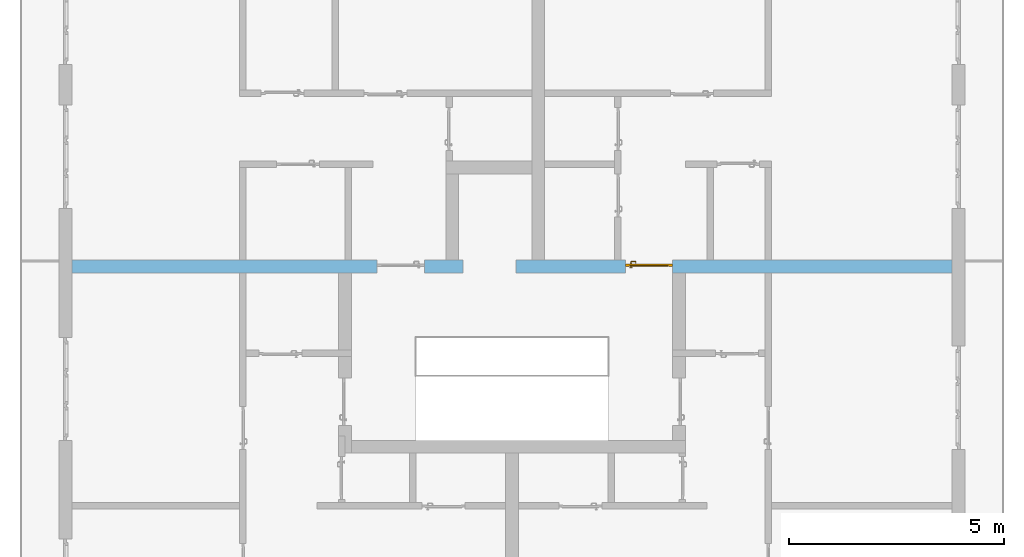
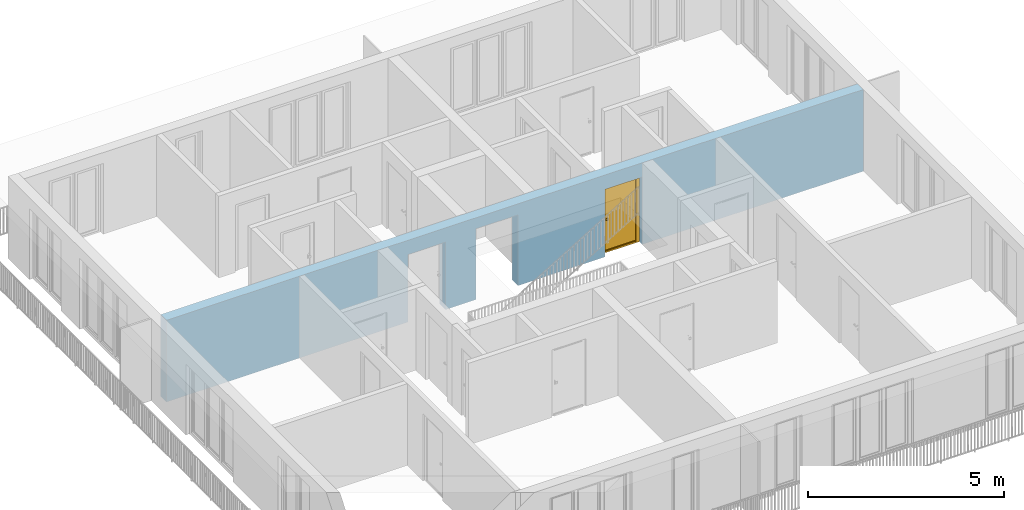
# One storey, part 17 of 54: 1 door, 3 openings, plus 1 element that does not belong to this part.
"""IFC4 building model written with IfcOpenShell, lengths in metres."""

import ifcopenshell
import ifcopenshell.guid

model = None  # the IFC model being written
_history = None  # IfcOwnerHistory: only IFC2X3 demands one
_inside = {}  # id of a spatial element -> (the spatial element, [elements in it])
_under = {}  # id of a project, library or spatial element -> (it, [spatial elements below it])
_declared = {}  # id of a project -> (the project, [libraries it declares])
_typed = {}  # id of a type object -> (the type object, [elements of that type])
_made_of = {}  # id of a material, layer set ... -> (it, [elements and type objects made of it])


def new_model(schema):
    """Start an empty IFC model of exactly this schema.

    Asked for "IFC4X3", IfcOpenShell would pick the latest addendum, in which some entities
    have other attributes; the version numbers below select the first issue.
    IFC2X3 requires an IfcOwnerHistory on every rooted entity: one is made here for all.
    """
    global model, _history
    if schema == "IFC4X3":
        model = ifcopenshell.file(schema_version=(4, 3, 0, 0))
    else:
        model = ifcopenshell.file(schema=schema)
    _inside.clear()
    _under.clear()
    _declared.clear()
    _typed.clear()
    _made_of.clear()
    _history = None
    if model.schema == "IFC2X3":
        org = make("IfcOrganization", Name="unknown")
        user = make(
            "IfcPersonAndOrganization",
            ThePerson=make("IfcPerson", FamilyName="unknown"),
            TheOrganization=org,
        )
        app = make(
            "IfcApplication",
            ApplicationDeveloper=org,
            Version="unknown",
            ApplicationFullName="unknown",
            ApplicationIdentifier="unknown",
        )
        _history = make(
            "IfcOwnerHistory",
            OwningUser=user,
            OwningApplication=app,
            ChangeAction="ADDED",
            CreationDate=0,
        )
    return model


def make(cls, **values):
    """One entity of the class cls with the attributes given. An attribute that is None is left unset."""
    return model.create_entity(
        cls, **{name: value for name, value in values.items() if value is not None}
    )


def entity(cls, *values):
    """Any entity or typed value of the class cls, its attributes in the order of the schema. None: left unset."""
    e = model.create_entity(cls)
    for i, value in enumerate(values):
        if value is not None:
            e[i] = value
    return e


def rooted(cls, **values):
    """An entity with a GlobalId (a new one), such as an element, a storey or a relation."""
    return make(cls, GlobalId=ifcopenshell.guid.new(), OwnerHistory=_history, **values)


def si_unit(unit_type, name, prefix=None):
    """IfcSIUnit, for example si_unit("LENGTHUNIT", "METRE", prefix="MILLI")."""
    return make("IfcSIUnit", UnitType=unit_type, Prefix=prefix, Name=name)


def converted_unit(unit_type, name, factor, base, dimensions=None, offset=None):
    """IfcConversionBasedUnit, such as the inch: factor (a typed value) times the base unit."""
    return make(
        "IfcConversionBasedUnit"
        if offset is None
        else "IfcConversionBasedUnitWithOffset",
        ConversionOffset=offset,
        Dimensions=None
        if dimensions is None
        else entity("IfcDimensionalExponents", *dimensions),
        UnitType=unit_type,
        Name=name,
        ConversionFactor=make(
            "IfcMeasureWithUnit", ValueComponent=factor, UnitComponent=base
        ),
    )


def derived_unit(unit_type, elements):
    """IfcDerivedUnit: a product of units, each with its exponent."""
    return make(
        "IfcDerivedUnit",
        Elements=[
            make("IfcDerivedUnitElement", Unit=unit, Exponent=power)
            for unit, power in elements
        ],
        UnitType=unit_type,
    )


def assignment(units):
    """IfcUnitAssignment: the units of a project."""
    return None if units is None else make("IfcUnitAssignment", Units=units)


def point(xyz):
    """IfcCartesianPoint."""
    return None if xyz is None else make("IfcCartesianPoint", Coordinates=xyz)


def direction(xyz):
    """IfcDirection."""
    return None if xyz is None else make("IfcDirection", DirectionRatios=xyz)


def frame(location, z_axis=None, x_axis=None):
    """IfcAxis2Placement3D, a coordinate frame: its origin and axes. An axis left out is left unset."""
    return make(
        "IfcAxis2Placement3D",
        Location=point(location),
        Axis=direction(z_axis),
        RefDirection=direction(x_axis),
    )


def origin_with_axes():
    """The frame at (0, 0, 0) with the z axis (0, 0, 1) and the x axis (1, 0, 0) written out."""
    return frame((0.0, 0.0, 0.0), z_axis=(0.0, 0.0, 1.0), x_axis=(1.0, 0.0, 0.0))


def place(relative_to, where):
    """IfcLocalPlacement: puts the frame where relative to a parent placement (None: the world)."""
    return make(
        "IfcLocalPlacement", PlacementRelTo=relative_to, RelativePlacement=where
    )


def context(
    kind, dimensions, precision=None, world=None, true_north=None, identifier=None
):
    """IfcGeometricRepresentationContext, for example the 3D "Model" context."""
    return make(
        "IfcGeometricRepresentationContext",
        ContextIdentifier=identifier,
        ContextType=kind,
        CoordinateSpaceDimension=dimensions,
        Precision=precision,
        WorldCoordinateSystem=world,
        TrueNorth=true_north,
    )


def subcontext(parent, identifier, kind, view, scale=None):
    """IfcGeometricRepresentationSubContext, for example "Body" below "Model"."""
    return make(
        "IfcGeometricRepresentationSubContext",
        ContextIdentifier=identifier,
        ContextType=kind,
        ParentContext=parent,
        TargetScale=scale,
        TargetView=view,
    )


def project(units=None, contexts=None):
    """IfcProject with its units and contexts."""
    return rooted(
        "IfcProject",
        Name="project",
        RepresentationContexts=contexts,
        UnitsInContext=assignment(units),
    )


def spatial(cls, under=None, at=None, **own):
    """A site, building, storey or space (cls), placed at a placement, below another one or the project."""
    s = rooted(cls, ObjectPlacement=at, **own)
    if under is not None:
        _under.setdefault(under.id(), (under, []))[1].append(s)
    return s


def point_list(points):
    """IfcCartesianPointList2D or 3D."""
    cls = (
        "IfcCartesianPointList2D" if len(points[0]) == 2 else "IfcCartesianPointList3D"
    )
    return make(cls, CoordList=points)


def polygons(points, faces, closed=None, point_numbers=None):
    """IfcPolygonalFaceSet: a face is its outer loop, then its inner loops; points numbered from 1."""
    made = []
    for loops in faces:
        if len(loops) == 1:
            made.append(make("IfcIndexedPolygonalFace", CoordIndex=loops[0]))
        else:
            made.append(
                make(
                    "IfcIndexedPolygonalFaceWithVoids",
                    CoordIndex=loops[0],
                    InnerCoordIndices=loops[1:],
                )
            )
    return make(
        "IfcPolygonalFaceSet",
        Coordinates=point_list(points),
        Closed=closed,
        Faces=made,
        PnIndex=point_numbers,
    )


def shape(context_of_items, identifier, shape_type, items):
    """IfcShapeRepresentation: the items that make up one representation, for example the "Body"."""
    return make(
        "IfcShapeRepresentation",
        ContextOfItems=context_of_items,
        RepresentationIdentifier=identifier,
        RepresentationType=shape_type,
        Items=items,
    )


def source(mapping_origin, context_of_items, identifier, shape_type, items):
    """IfcRepresentationMap: a shape defined once, which mapped items show again and again."""
    return make(
        "IfcRepresentationMap",
        MappingOrigin=mapping_origin,
        MappedRepresentation=shape(context_of_items, identifier, shape_type, items),
    )


def transform(
    local_origin,
    x_axis=None,
    y_axis=None,
    z_axis=None,
    scale=None,
    scale2=None,
    scale3=None,
    uniform=True,
):
    """IfcCartesianTransformationOperator3D, or its non-uniform kind. x_axis, y_axis, z_axis: its Axis1, 2, 3."""
    if uniform:
        return make(
            "IfcCartesianTransformationOperator3D",
            Axis1=direction(x_axis),
            Axis2=direction(y_axis),
            LocalOrigin=point(local_origin),
            Scale=scale,
            Axis3=direction(z_axis),
        )
    return make(
        "IfcCartesianTransformationOperator3DnonUniform",
        Axis1=direction(x_axis),
        Axis2=direction(y_axis),
        LocalOrigin=point(local_origin),
        Scale=scale,
        Axis3=direction(z_axis),
        Scale2=scale2,
        Scale3=scale3,
    )


def mapped(mapping_source, mapping_target):
    """IfcMappedItem: shows the shape of a source again, moved by a transform."""
    return make(
        "IfcMappedItem", MappingSource=mapping_source, MappingTarget=mapping_target
    )


def material(Name=None, Category=None):
    """IfcMaterial."""
    return make("IfcMaterial", Name=Name, Category=Category)


def made_of(thing, what):
    """Note that an element or type object is made of a material, layer set ...; save() writes the relation."""
    if what is not None:
        _made_of.setdefault(what.id(), (what, []))[1].append(thing)
    return thing


def type_object(cls, material=None, **own):
    """A type object (cls), such as IfcWallType, which elements share."""
    return made_of(rooted(cls, **own), material)


def element(
    cls,
    number,
    at=None,
    inside=None,
    cuts=None,
    type_object=None,
    material=None,
    context=None,
    identifier="Body",
    shape_type=None,
    held_by="IfcProductDefinitionShape",
    body=None,
    shapes=None,
    **own,
):
    """One element of the class cls, such as IfcWall. Its Tag is "e" and its number.

    at: its placement. inside: the storey or other place that contains it. cuts: it is an
    opening in that element (IfcRelVoidsElement). A single representation is given by context,
    identifier, shape_type and body (its items); several are given by shapes. held_by: the class
    of the entity that holds the representations. save() writes the other relations.
    """
    e = rooted(cls, Tag="e%d" % number, ObjectPlacement=at, **own)
    if body is not None:
        shapes = [shape(context, identifier, shape_type, body)]
    if shapes is not None:
        e.Representation = make(held_by, Representations=shapes)
    if inside is not None:
        _inside.setdefault(inside.id(), (inside, []))[1].append(e)
    if cuts is not None:
        rooted(
            "IfcRelVoidsElement", RelatingBuildingElement=cuts, RelatedOpeningElement=e
        )
    if type_object is not None:
        _typed.setdefault(type_object.id(), (type_object, []))[1].append(e)
    return made_of(e, material)


def fill(opening, filler):
    """IfcRelFillsElement: the door or window that sits in an opening."""
    return rooted(
        "IfcRelFillsElement",
        RelatingOpeningElement=opening,
        RelatedBuildingElement=filler,
    )


def aggregate(whole, parts):
    """IfcRelAggregates: a whole, such as a stair, and the parts it consists of."""
    return rooted("IfcRelAggregates", RelatingObject=whole, RelatedObjects=parts)


def save(model, path):
    """Write the relations noted so far, then the file.

    IfcRelAggregates (storeys below a building ...), IfcRelContainedInSpatialStructure (elements
    in a storey), IfcRelDefinesByType, IfcRelAssociatesMaterial and IfcRelDeclares: one each for
    every whole, place, type object, material and project.
    """
    for whole, parts in _under.values():
        aggregate(whole, parts)
    for where, things in _inside.values():
        rooted(
            "IfcRelContainedInSpatialStructure",
            RelatedElements=things,
            RelatingStructure=where,
        )
    for kind, things in _typed.values():
        rooted("IfcRelDefinesByType", RelatedObjects=things, RelatingType=kind)
    for what, things in _made_of.values():
        rooted("IfcRelAssociatesMaterial", RelatedObjects=things, RelatingMaterial=what)
    for by, libraries in _declared.values():
        rooted("IfcRelDeclares", RelatingContext=by, RelatedDefinitions=libraries)
    model.write(path)


model = new_model("IFC4")

# Units and contexts
model_context = context("Model", 3, precision=1e-05, world=origin_with_axes(), true_north=direction((0.0, 1.0)))
body_context = subcontext(model_context, "Body", "Model", "MODEL_VIEW")
ifc_project = project(units=[si_unit("LENGTHUNIT", "METRE"), si_unit("AREAUNIT", "SQUARE_METRE"), si_unit("VOLUMEUNIT", "CUBIC_METRE"), converted_unit("PLANEANGLEUNIT", "DEGREE", entity("IfcPlaneAngleMeasure", 0.0174532925199), si_unit("PLANEANGLEUNIT", "RADIAN"), dimensions=[0, 0, 0, 0, 0, 0, 0]), converted_unit("TIMEUNIT", "Year", entity("IfcTimeMeasure", 31556926.0), si_unit("TIMEUNIT", "SECOND"), dimensions=[0, 0, 1, 0, 0, 0, 0]), si_unit("MASSUNIT", "GRAM", prefix="KILO"), si_unit("THERMODYNAMICTEMPERATUREUNIT", "DEGREE_CELSIUS"), si_unit("LUMINOUSINTENSITYUNIT", "LUMEN"), si_unit("ENERGYUNIT", "JOULE", prefix="MEGA"), derived_unit("THERMALCONDUCTANCEUNIT", [(si_unit("POWERUNIT", "WATT"), 1), (si_unit("LENGTHUNIT", "METRE"), -1), (si_unit("THERMODYNAMICTEMPERATUREUNIT", "KELVIN"), -1)]), derived_unit("SPECIFICHEATCAPACITYUNIT", [(si_unit("ENERGYUNIT", "JOULE"), 1), (si_unit("MASSUNIT", "GRAM", prefix="KILO"), -1), (si_unit("THERMODYNAMICTEMPERATUREUNIT", "KELVIN"), -1)]), derived_unit("MASSDENSITYUNIT", [(si_unit("MASSUNIT", "GRAM", prefix="KILO"), 1), (si_unit("VOLUMEUNIT", "CUBIC_METRE"), -1)])], contexts=[model_context])

# Site, building, storey
site_placement = place(None, origin_with_axes())
site = spatial("IfcSite", under=ifc_project, at=site_placement, CompositionType="ELEMENT")
building_placement = place(site_placement, origin_with_axes())
building = spatial("IfcBuilding", under=site, at=building_placement, CompositionType="ELEMENT")
storey_placement = place(building_placement, frame((0.0, 0.0, 6.29), z_axis=(0.0, 0.0, 1.0), x_axis=(1.0, 0.0, 0.0)))
storey = spatial("IfcBuildingStorey", under=building, at=storey_placement, Name="2. Geschoss", CompositionType="ELEMENT", Elevation=6.29)

# Wall, openings, door
ifc_material = material()
wall_type = type_object("IfcWallType", Name="300", PredefinedType="NOTDEFINED")
wall_placement = place(storey_placement, frame((-11.7421993804, 1.37118776896, 0.0), z_axis=(0.0, 0.0, 1.0), x_axis=(1.0, 0.0, 0.0)))
wall = element("IfcWall", 1, at=wall_placement, inside=storey, type_object=wall_type, material=ifc_material, Name="Wand-001", PredefinedType="NOTDEFINED", context=body_context, shape_type="Tessellation", body=[
    polygons([(9.4, 0.3, 2.2), (9.4, 0.3, 0.0), (8.5, 0.3, 0.0), (8.5, 0.3, 2.1), (7.4, 0.3, 2.1), (7.4, 0.3, 0.0), (0.3, 0.3, 0.0), (0.3, 0.3, 2.54), (20.78, 0.3, 2.54), (20.78, 0.3, 0.0), (14.28, 0.3, 0.0), (14.28, 0.3, 2.1), (13.18, 0.3, 2.1), (13.18, 0.3, 0.0), (10.63, 0.3, 0.0), (10.63, 0.3, 2.2), (9.4, 0.0, 2.2), (9.4, 0.0, 0.0), (8.5, 0.0, 0.0), (8.5, 0.0, 2.1), (7.4, 0.0, 2.1), (7.4, 0.0, 0.0), (0.3, 0.0, 0.0), (0.3, 0.0, 2.54), (20.78, 0.0, 2.54), (20.78, 0.0, 0.0), (14.28, 0.0, 0.0), (14.28, 0.0, 2.1), (13.18, 0.0, 2.1), (13.18, 0.0, 0.0), (10.63, 0.0, 0.0), (10.63, 0.0, 2.2)], [[[1, 2, 3, 4, 5, 6, 7, 8, 9, 10, 11, 12, 13, 14, 15, 16]], [[2, 1, 17, 18]], [[2, 18, 19, 3]], [[20, 4, 3, 19]], [[21, 5, 4, 20]], [[22, 6, 5, 21]], [[7, 6, 22, 23]], [[24, 8, 7, 23]], [[25, 9, 8, 24]], [[9, 25, 26, 10]], [[10, 26, 27, 11]], [[11, 27, 28, 12]], [[12, 28, 29, 13]], [[13, 29, 30, 14]], [[31, 15, 14, 30]], [[16, 15, 31, 32]], [[1, 16, 32, 17]], [[32, 31, 30, 29, 28, 27, 26, 25, 24, 23, 22, 21, 20, 19, 18, 17]]], closed=True),
])
opening_1_placement = place(wall_placement, frame((7.95, 0.0, 0.0), z_axis=(0.0, 0.0, 1.0), x_axis=(1.0, 0.0, 0.0)))
element("IfcOpeningElement", 2, at=opening_1_placement, cuts=wall, context=body_context, identifier="Reference", shape_type="Tessellation", body=[
    polygons([(0.55, 0.15, 0.0), (0.55, 0.15, 2.1), (0.55, -0.001, 2.1), (0.55, -0.001, 0.0), (0.55, 0.301, 0.0), (0.55, 0.301, 2.1), (-0.55, 0.15, 2.1), (-0.55, -0.001, 2.1), (-0.55, 0.301, 2.1), (-0.55, -0.001, 0.0), (-0.55, 0.15, 0.0), (-0.55, 0.301, 0.0)], [[[1, 2, 3, 4]], [[2, 1, 5, 6]], [[7, 8, 3, 2, 6, 9]], [[8, 10, 4, 3]], [[1, 4, 10, 11, 12, 5]], [[6, 5, 12, 9]], [[7, 11, 10, 8]], [[11, 7, 9, 12]]], closed=True),
])
opening_2_placement = place(wall_placement, frame((13.73, 0.0, 0.0), z_axis=(0.0, 0.0, 1.0), x_axis=(1.0, 0.0, 0.0)))
opening_2 = element("IfcOpeningElement", 3, at=opening_2_placement, cuts=wall, context=body_context, identifier="Reference", shape_type="Tessellation", body=[
    polygons([(0.55, 0.15, 0.0), (0.55, 0.15, 2.1), (0.55, -0.001, 2.1), (0.55, -0.001, 0.0), (0.55, 0.301, 0.0), (0.55, 0.301, 2.1), (-0.55, 0.15, 2.1), (-0.55, -0.001, 2.1), (-0.55, 0.301, 2.1), (-0.55, -0.001, 0.0), (-0.55, 0.15, 0.0), (-0.55, 0.301, 0.0)], [[[1, 2, 3, 4]], [[2, 1, 5, 6]], [[7, 8, 3, 2, 6, 9]], [[8, 10, 4, 3]], [[1, 4, 10, 11, 12, 5]], [[6, 5, 12, 9]], [[7, 11, 10, 8]], [[11, 7, 9, 12]]], closed=True),
])
opening_3_placement = place(wall_placement, frame((10.015, 0.0, 0.0), z_axis=(0.0, 0.0, 1.0), x_axis=(1.0, 0.0, 0.0)))
element("IfcOpeningElement", 4, at=opening_3_placement, cuts=wall, context=body_context, identifier="Reference", shape_type="Tessellation", body=[
    polygons([(-0.615, -0.001, 2.2), (-0.615, -0.001, 0.0), (0.615, -0.001, 0.0), (0.615, -0.001, 2.2), (-0.615, 0.301, 2.2), (-0.615, 0.301, 0.0), (0.615, 0.301, 0.0), (0.615, 0.301, 2.2)], [[[1, 2, 3, 4]], [[5, 6, 2, 1]], [[6, 7, 3, 2]], [[7, 8, 4, 3]], [[8, 5, 1, 4]], [[7, 6, 5, 8]]], closed=True),
])
door_type = type_object("IfcDoorType", Name="Eingang 01 1-Fl 26", OperationType="SINGLE_SWING_RIGHT", PredefinedType="DOOR")
shared_shape = source(origin_with_axes(), body_context, "Body", "Tessellation", [
    polygons([(0.55, -0.05, 0.0), (0.55, -0.03, 0.0), (0.55, -0.03, 2.1), (0.55, -0.05, 2.1), (0.45, -0.05, 0.0), (0.45, -0.03, 0.0), (0.45, -0.03, 2.0), (0.1301, -0.03, 2.0), (0.0001, -0.03, 2.0), (-0.45, -0.03, 2.0), (-0.45, -0.03, 0.0), (-0.55, -0.03, 0.0), (-0.55, -0.03, 2.1), (-0.55, -0.05, 2.1), (-0.55, -0.05, 0.0), (-0.45, -0.05, 0.0), (-0.45, -0.05, 2.0), (0.0001, -0.05, 2.0), (0.1301, -0.05, 2.0), (0.45, -0.05, 2.0)], [[[1, 2, 3, 4]], [[5, 6, 2, 1]], [[2, 6, 7, 8, 9, 10, 11, 12, 13, 3]], [[4, 3, 13, 14]], [[1, 4, 14, 15, 16, 17, 18, 19, 20, 5]], [[20, 7, 6, 5]], [[19, 8, 7, 20]], [[18, 9, 8, 19]], [[17, 10, 9, 18]], [[16, 11, 10, 17]], [[15, 12, 11, 16]], [[14, 13, 12, 15]]], closed=True),
    polygons([(0.55, -0.03, 0.0), (0.55, 0.0, 0.0), (0.55, 0.0, 2.1), (0.55, -0.03, 2.1), (0.48, -0.03, 0.0), (0.48, 0.0, 0.0), (0.48, 0.0, 2.03), (0.1001, 0.0, 2.03), (0.0301, 0.0, 2.03), (-0.48, 0.0, 2.03), (-0.48, 0.0, 0.0), (-0.55, 0.0, 0.0), (-0.55, 0.0, 2.1), (-0.55, -0.03, 2.1), (-0.55, -0.03, 0.0), (-0.48, -0.03, 0.0), (-0.48, -0.03, 2.03), (0.0301, -0.03, 2.03), (0.1001, -0.03, 2.03), (0.48, -0.03, 2.03)], [[[1, 2, 3, 4]], [[5, 6, 2, 1]], [[2, 6, 7, 8, 9, 10, 11, 12, 13, 3]], [[4, 3, 13, 14]], [[1, 4, 14, 15, 16, 17, 18, 19, 20, 5]], [[20, 7, 6, 5]], [[19, 8, 7, 20]], [[18, 9, 8, 19]], [[17, 10, 9, 18]], [[16, 11, 10, 17]], [[15, 12, 11, 16]], [[14, 13, 12, 15]]], closed=True),
    polygons([(0.48, 0.01, 0.0), (-0.48, 0.01, 0.0), (-0.48, 0.01, 2.03), (0.48, 0.01, 2.03), (0.48, -0.03, 0.0), (-0.48, -0.03, 0.0), (-0.48, -0.03, 2.03), (0.48, -0.03, 2.03)], [[[1, 2, 3, 4]], [[2, 1, 5, 6]], [[3, 2, 6, 7]], [[4, 3, 7, 8]], [[1, 4, 8, 5]], [[6, 5, 8, 7]]], closed=True),
    polygons([(0.445, -0.05, 0.0), (0.445, -0.05, 0.05), (-0.445, -0.05, 0.05), (-0.445, -0.05, 0.0), (0.445, -0.03, 0.0), (0.445, -0.03, 0.07), (0.445, -0.035, 0.07), (-0.445, -0.035, 0.07), (-0.445, -0.03, 0.07), (-0.445, -0.03, 0.0)], [[[1, 2, 3, 4]], [[1, 5, 6, 7, 2]], [[2, 7, 8, 3]], [[4, 3, 8, 9, 10]], [[5, 1, 4, 10]], [[6, 5, 10, 9]], [[7, 6, 9, 8]]], closed=True),
    polygons([(-0.4335, 0.02, 1.0733826859), (-0.4335, 0.0199, 1.0733826859), (-0.42, 0.0199, 1.077), (-0.42, 0.02, 1.077), (-0.443382685902, 0.02, 1.0635), (-0.443382685902, 0.0199, 1.0635), (-0.4335, 0.0101, 1.0733826859), (-0.42, 0.0101, 1.077), (-0.4065, 0.0199, 1.0733826859), (-0.4065, 0.02, 1.0733826859), (-0.396617314098, 0.02, 1.0635), (-0.393, 0.02, 1.05), (-0.396617314098, 0.02, 1.0365), (-0.4065, 0.02, 1.0266173141), (-0.42, 0.02, 1.023), (-0.4335, 0.02, 1.0266173141), (-0.443382685902, 0.02, 1.0365), (-0.447, 0.02, 1.05), (-0.447, 0.0199, 1.05), (-0.443382685902, 0.0101, 1.0635), (-0.4335, 0.01, 1.0733826859), (-0.42, 0.01, 1.077), (-0.4065, 0.0101, 1.0733826859), (-0.396617314098, 0.0199, 1.0635), (-0.393, 0.0199, 1.05), (-0.396617314098, 0.0199, 1.0365), (-0.4065, 0.0199, 1.0266173141), (-0.42, 0.0199, 1.023), (-0.4335, 0.0199, 1.0266173141), (-0.443382685902, 0.0199, 1.0365), (-0.447, 0.0101, 1.05), (-0.443382685902, 0.01, 1.0635), (-0.447, 0.01, 1.05), (-0.443382685902, 0.01, 1.0365), (-0.4335, 0.01, 1.0266173141), (-0.42, 0.01, 1.023), (-0.4065, 0.01, 1.0266173141), (-0.396617314098, 0.01, 1.0365), (-0.393, 0.01, 1.05), (-0.396617314098, 0.01, 1.0635), (-0.4065, 0.01, 1.0733826859), (-0.396617314098, 0.0101, 1.0635), (-0.393, 0.0101, 1.05), (-0.396617314098, 0.0101, 1.0365), (-0.4065, 0.0101, 1.0266173141), (-0.42, 0.0101, 1.023), (-0.4335, 0.0101, 1.0266173141), (-0.443382685902, 0.0101, 1.0365)], [[[1, 2, 3, 4]], [[5, 6, 2, 1]], [[2, 7, 8, 3]], [[4, 3, 9, 10]], [[4, 10, 11, 12, 13, 14, 15, 16, 17, 18, 5, 1]], [[18, 19, 6, 5]], [[6, 20, 7, 2]], [[7, 21, 22, 8]], [[3, 8, 23, 9]], [[10, 9, 24, 11]], [[11, 24, 25, 12]], [[12, 25, 26, 13]], [[13, 26, 27, 14]], [[14, 27, 28, 15]], [[15, 28, 29, 16]], [[16, 29, 30, 17]], [[17, 30, 19, 18]], [[19, 31, 20, 6]], [[20, 32, 21, 7]], [[22, 21, 32, 33, 34, 35, 36, 37, 38, 39, 40, 41]], [[8, 22, 41, 23]], [[9, 23, 42, 24]], [[24, 42, 43, 25]], [[25, 43, 44, 26]], [[26, 44, 45, 27]], [[27, 45, 46, 28]], [[28, 46, 47, 29]], [[29, 47, 48, 30]], [[30, 48, 31, 19]], [[31, 33, 32, 20]], [[48, 34, 33, 31]], [[47, 35, 34, 48]], [[46, 36, 35, 47]], [[45, 37, 36, 46]], [[44, 38, 37, 45]], [[43, 39, 38, 44]], [[42, 40, 39, 43]], [[23, 41, 40, 42]]], closed=True),
    polygons([(-0.412532169224, 0.019, 0.959692280177), (-0.415, 0.019, 0.9544), (-0.415, 0.019, 0.952886751346), (-0.397569942042, 0.019, 0.96295), (-0.40705, 0.019, 0.972430057958), (-0.413279754556, 0.019, 0.961639806549), (-0.412532169224, 0.02, 0.959692280177), (-0.415, 0.02, 0.9544), (-0.415, 0.02, 0.952886751346), (-0.415, 0.02, 0.95), (-0.415, 0.02, 0.947113248654), (-0.415, 0.02, 0.941339745962), (-0.415, 0.02, 0.9375), (-0.415, 0.019, 0.9375), (-0.415, 0.019, 0.941339745962), (-0.415, 0.019, 0.947113248654), (-0.415, 0.019, 0.95), (-0.3941, 0.019, 0.95), (-0.397483339502, 0.019, 0.963), (-0.407, 0.019, 0.972516660498), (-0.414624817685, 0.019, 0.965143815798), (-0.42, 0.019, 0.9759), (-0.42, 0.019, 0.967425445323), (-0.414624817685, 0.02, 0.965143815798), (-0.413279754556, 0.02, 0.961639806549), (-0.40655, 0.02, 0.973296083362), (-0.396703916638, 0.02, 0.96345), (-0.3931, 0.02, 0.95), (-0.396703916638, 0.02, 0.93655), (-0.40655, 0.02, 0.926703916638), (-0.42, 0.02, 0.9231), (-0.42, 0.02, 0.9325), (-0.416464466094, 0.02, 0.933964466094), (-0.416464466094, 0.019, 0.933964466094), (-0.40705, 0.019, 0.927569942042), (-0.42, 0.019, 0.9325), (-0.42, 0.019, 0.9241), (-0.397569942042, 0.019, 0.93705), (-0.394, 0.019, 0.95), (-0.397483339502, 0.0189, 0.963), (-0.407, 0.0189, 0.972516660498), (-0.42, 0.019, 0.976), (-0.425375182315, 0.019, 0.965143815798), (-0.43295, 0.019, 0.972430057958), (-0.426720245444, 0.019, 0.961639806549), (-0.42, 0.02, 0.967425445323), (-0.42, 0.02, 0.9769), (-0.396617314098, 0.02, 0.9635), (-0.4065, 0.02, 0.973382685902), (-0.393, 0.02, 0.95), (-0.396617314098, 0.02, 0.9365), (-0.4065, 0.02, 0.926617314098), (-0.43345, 0.02, 0.926703916638), (-0.425, 0.02, 0.941339745962), (-0.425, 0.02, 0.9375), (-0.423535533906, 0.02, 0.933964466094), (-0.42, 0.02, 0.923), (-0.423535533906, 0.019, 0.933964466094), (-0.425, 0.019, 0.9375), (-0.425, 0.019, 0.941339745962), (-0.43295, 0.019, 0.927569942042), (-0.42, 0.019, 0.924), (-0.407, 0.019, 0.927483339502), (-0.397483339502, 0.019, 0.937), (-0.394, 0.0189, 0.95), (-0.397483339502, 0.0101, 0.963), (-0.407, 0.0101, 0.972516660498), (-0.42, 0.0189, 0.976), (-0.433, 0.019, 0.972516660498), (-0.425375182315, 0.02, 0.965143815798), (-0.427467830776, 0.019, 0.959692280177), (-0.442430057958, 0.019, 0.96295), (-0.425, 0.019, 0.952886751346), (-0.425, 0.019, 0.9544), (-0.427467830776, 0.02, 0.959692280177), (-0.426720245444, 0.02, 0.961639806549), (-0.43345, 0.02, 0.973296083362), (-0.42, 0.02, 0.977), (-0.396617314098, 0.0199, 0.9635), (-0.4065, 0.0199, 0.973382685902), (-0.393, 0.0199, 0.95), (-0.396617314098, 0.0199, 0.9365), (-0.4065, 0.0199, 0.926617314098), (-0.443296083362, 0.02, 0.93655), (-0.425, 0.02, 0.947113248654), (-0.425, 0.02, 0.9544), (-0.425, 0.019, 0.95), (-0.425, 0.019, 0.947113248654), (-0.425, 0.02, 0.95), (-0.425, 0.02, 0.952886751346), (-0.4335, 0.02, 0.926617314098), (-0.42, 0.0199, 0.923), (-0.442430057958, 0.019, 0.93705), (-0.433, 0.019, 0.927483339502), (-0.42, 0.0189, 0.924), (-0.407, 0.0189, 0.927483339502), (-0.397483339502, 0.0189, 0.937), (-0.394, 0.0101, 0.95), (-0.397483339502, 0.01, 0.963), (-0.407, 0.01, 0.972516660498), (-0.42, 0.0101, 0.976), (-0.433, 0.0189, 0.972516660498), (-0.442516660498, 0.019, 0.963), (-0.4459, 0.019, 0.95), (-0.443296083362, 0.02, 0.96345), (-0.4335, 0.02, 0.973382685902), (-0.42, 0.0199, 0.977), (-0.396617314098, 0.0101, 0.9635), (-0.4065, 0.0101, 0.973382685902), (-0.393, 0.0101, 0.95), (-0.396617314098, 0.0101, 0.9365), (-0.4065, 0.0101, 0.926617314098), (-0.443382685902, 0.02, 0.9365), (-0.4469, 0.02, 0.95), (-0.4335, 0.0199, 0.926617314098), (-0.42, 0.0101, 0.923), (-0.442516660498, 0.019, 0.937), (-0.433, 0.0189, 0.927483339502), (-0.42, 0.0101, 0.924), (-0.407, 0.0101, 0.927483339502), (-0.397483339502, 0.0101, 0.937), (-0.394, 0.01, 0.95), (-0.397396736961, 0.01, 0.96305), (-0.40695, 0.01, 0.972603263039), (-0.42, 0.01, 0.976), (-0.433, 0.0101, 0.972516660498), (-0.442516660498, 0.0189, 0.963), (-0.446, 0.019, 0.95), (-0.443382685902, 0.02, 0.9635), (-0.4335, 0.0199, 0.973382685902), (-0.42, 0.0101, 0.977), (-0.396617314098, 0.01, 0.9635), (-0.4065, 0.01, 0.973382685902), (-0.393, 0.01, 0.95), (-0.396617314098, 0.01, 0.9365), (-0.4065, 0.01, 0.926617314098), (-0.447, 0.02, 0.95), (-0.443382685902, 0.0199, 0.9365), (-0.4335, 0.0101, 0.926617314098), (-0.42, 0.01, 0.923), (-0.442516660498, 0.0189, 0.937), (-0.433, 0.0101, 0.927483339502), (-0.42, 0.01, 0.924), (-0.407, 0.01, 0.927483339502), (-0.397483339502, 0.01, 0.937), (-0.3939, 0.01, 0.95), (-0.396703916638, 0.01, 0.96345), (-0.40655, 0.01, 0.973296083362), (-0.42, 0.01, 0.9761), (-0.433, 0.01, 0.972516660498), (-0.442516660498, 0.0101, 0.963), (-0.446, 0.0189, 0.95), (-0.443382685902, 0.0199, 0.9635), (-0.4335, 0.0101, 0.973382685902), (-0.42, 0.01, 0.977), (-0.3931, 0.01, 0.95), (-0.396703916638, 0.01, 0.93655), (-0.40655, 0.01, 0.926703916638), (-0.447, 0.0199, 0.95), (-0.443382685902, 0.0101, 0.9365), (-0.4335, 0.01, 0.926617314098), (-0.42, 0.01, 0.9231), (-0.442516660498, 0.0101, 0.937), (-0.433, 0.01, 0.927483339502), (-0.42, 0.01, 0.9239), (-0.40695, 0.01, 0.927396736961), (-0.397396736961, 0.01, 0.93695), (-0.42, 0.01, 0.9769), (-0.43305, 0.01, 0.972603263039), (-0.442516660498, 0.01, 0.963), (-0.446, 0.0101, 0.95), (-0.443382685902, 0.0101, 0.9635), (-0.4335, 0.01, 0.973382685902), (-0.447, 0.0101, 0.95), (-0.443382685902, 0.01, 0.9365), (-0.43345, 0.01, 0.926703916638), (-0.442516660498, 0.01, 0.937), (-0.43305, 0.01, 0.927396736961), (-0.43345, 0.01, 0.973296083362), (-0.442603263039, 0.01, 0.96305), (-0.446, 0.01, 0.95), (-0.443382685902, 0.01, 0.9635), (-0.447, 0.01, 0.95), (-0.443296083362, 0.01, 0.93655), (-0.442603263039, 0.01, 0.93695), (-0.443296083362, 0.01, 0.96345), (-0.4461, 0.01, 0.95), (-0.4469, 0.01, 0.95)], [[[1, 2, 3, 4, 5, 6]], [[2, 1, 7, 8]], [[2, 8, 9, 10, 11, 12, 13, 14, 15, 16, 17, 3]], [[17, 18, 4, 3]], [[4, 19, 20, 5]], [[21, 6, 5, 22, 23]], [[1, 6, 21, 24, 25, 7]], [[7, 25, 26, 27, 9, 8]], [[9, 27, 28, 10]], [[10, 28, 29, 11]], [[11, 29, 30, 12]], [[31, 32, 33, 13, 12, 30]], [[14, 13, 33, 34]], [[35, 15, 14, 34, 36, 37]], [[15, 35, 38, 16]], [[16, 38, 18, 17]], [[18, 39, 19, 4]], [[19, 40, 41, 20]], [[5, 20, 42, 22]], [[43, 23, 22, 44, 45]], [[21, 23, 46, 24]], [[24, 46, 47, 26, 25]], [[48, 27, 26, 49]], [[50, 28, 27, 48]], [[51, 29, 28, 50]], [[52, 30, 29, 51]], [[53, 54, 55, 56, 32, 31]], [[34, 33, 32, 36]], [[57, 31, 30, 52]], [[37, 36, 58, 59, 60, 61]], [[37, 62, 63, 35]], [[35, 63, 64, 38]], [[38, 64, 39, 18]], [[39, 65, 40, 19]], [[40, 66, 67, 41]], [[20, 41, 68, 42]], [[22, 42, 69, 44]], [[23, 43, 70, 46]], [[71, 45, 44, 72, 73, 74]], [[43, 45, 71, 75, 76, 70]], [[70, 76, 77, 47, 46]], [[49, 26, 47, 78]], [[79, 48, 49, 80]], [[81, 50, 48, 79]], [[82, 51, 50, 81]], [[83, 52, 51, 82]], [[54, 53, 84, 85]], [[86, 74, 73, 87, 88, 60, 59, 55, 54, 85, 89, 90]], [[58, 56, 55, 59]], [[36, 32, 56, 58]], [[91, 53, 31, 57]], [[92, 57, 52, 83]], [[88, 93, 61, 60]], [[61, 94, 62, 37]], [[62, 95, 96, 63]], [[63, 96, 97, 64]], [[64, 97, 65, 39]], [[65, 98, 66, 40]], [[66, 99, 100, 67]], [[41, 67, 101, 68]], [[42, 68, 102, 69]], [[44, 69, 103, 72]], [[73, 72, 104, 87]], [[71, 74, 86, 75]], [[75, 86, 90, 105, 77, 76]], [[78, 47, 77, 106]], [[80, 49, 78, 107]], [[108, 79, 80, 109]], [[110, 81, 79, 108]], [[111, 82, 81, 110]], [[112, 83, 82, 111]], [[113, 84, 53, 91]], [[85, 84, 114, 89]], [[87, 104, 93, 88]], [[89, 114, 105, 90]], [[115, 91, 57, 92]], [[116, 92, 83, 112]], [[93, 117, 94, 61]], [[94, 118, 95, 62]], [[95, 119, 120, 96]], [[96, 120, 121, 97]], [[97, 121, 98, 65]], [[98, 122, 99, 66]], [[99, 123, 124, 100]], [[67, 100, 125, 101]], [[68, 101, 126, 102]], [[69, 102, 127, 103]], [[72, 103, 128, 104]], [[106, 77, 105, 129]], [[107, 78, 106, 130]], [[109, 80, 107, 131]], [[132, 108, 109, 133]], [[134, 110, 108, 132]], [[135, 111, 110, 134]], [[136, 112, 111, 135]], [[137, 114, 84, 113]], [[138, 113, 91, 115]], [[104, 128, 117, 93]], [[129, 105, 114, 137]], [[139, 115, 92, 116]], [[140, 116, 112, 136]], [[117, 141, 118, 94]], [[118, 142, 119, 95]], [[119, 143, 144, 120]], [[120, 144, 145, 121]], [[121, 145, 122, 98]], [[122, 146, 123, 99]], [[123, 147, 148, 124]], [[100, 124, 149, 125]], [[101, 125, 150, 126]], [[102, 126, 151, 127]], [[103, 127, 152, 128]], [[130, 106, 129, 153]], [[131, 107, 130, 154]], [[133, 109, 131, 155]], [[147, 132, 133, 148]], [[156, 134, 132, 147]], [[157, 135, 134, 156]], [[158, 136, 135, 157]], [[159, 137, 113, 138]], [[160, 138, 115, 139]], [[128, 152, 141, 117]], [[153, 129, 137, 159]], [[161, 139, 116, 140]], [[162, 140, 136, 158]], [[141, 163, 142, 118]], [[142, 164, 143, 119]], [[143, 165, 166, 144]], [[144, 166, 167, 145]], [[145, 167, 146, 122]], [[146, 156, 147, 123]], [[124, 148, 168, 149]], [[125, 149, 169, 150]], [[126, 150, 170, 151]], [[127, 151, 171, 152]], [[154, 130, 153, 172]], [[155, 131, 154, 173]], [[148, 133, 155, 168]], [[167, 157, 156, 146]], [[166, 158, 157, 167]], [[174, 159, 138, 160]], [[175, 160, 139, 161]], [[152, 171, 163, 141]], [[172, 153, 159, 174]], [[176, 161, 140, 162]], [[165, 162, 158, 166]], [[163, 177, 164, 142]], [[164, 178, 165, 143]], [[149, 168, 179, 169]], [[150, 169, 180, 170]], [[151, 170, 181, 171]], [[173, 154, 172, 182]], [[168, 155, 173, 179]], [[183, 174, 160, 175]], [[184, 175, 161, 176]], [[171, 181, 177, 163]], [[182, 172, 174, 183]], [[178, 176, 162, 165]], [[177, 185, 178, 164]], [[169, 179, 186, 180]], [[170, 180, 187, 181]], [[179, 173, 182, 186]], [[188, 183, 175, 184]], [[185, 184, 176, 178]], [[181, 187, 185, 177]], [[186, 182, 183, 188]], [[180, 186, 188, 187]], [[187, 188, 184, 185]]], closed=True),
    polygons([(-0.43, 0.02, 1.05), (-0.43, 0.0509849140336, 1.05), (-0.427071067812, 0.050696439392, 1.04292893219), (-0.427071067812, 0.02, 1.04292893219), (-0.427071067812, 0.02, 1.05707106781), (-0.427071067812, 0.050696439392, 1.05707106781), (-0.428277987014, 0.0596420579258, 1.05), (-0.425518993221, 0.0584992452783, 1.04292893219), (-0.42, 0.05, 1.04), (-0.42, 0.02, 1.04), (-0.42, 0.02, 1.06), (-0.42, 0.05, 1.06), (-0.425518993221, 0.0584992452783, 1.05707106781), (-0.422816199938, 0.0678161999379, 1.05), (-0.420704557509, 0.0657045575088, 1.04292893219), (-0.418858192988, 0.0557402514855, 1.04), (-0.412928932188, 0.049303560608, 1.04292893219), (-0.412928932188, 0.02, 1.04292893219), (-0.412928932188, 0.02, 1.05707106781), (-0.412928932188, 0.049303560608, 1.05707106781), (-0.418858192988, 0.0557402514855, 1.06), (-0.420704557509, 0.0657045575088, 1.05707106781), (-0.414642057926, 0.0732779870137, 1.05), (-0.413499245278, 0.0705189932208, 1.04292893219), (-0.415606601718, 0.0606066017178, 1.04), (-0.412197392755, 0.0529812576926, 1.04292893219), (-0.41, 0.0490150859664, 1.05), (-0.41, 0.02, 1.05), (-0.412197392755, 0.0529812576926, 1.05707106781), (-0.415606601718, 0.0606066017178, 1.06), (-0.413499245278, 0.0705189932208, 1.05707106781), (-0.405984914034, 0.075, 1.05), (-0.405696439392, 0.0720710678119, 1.04292893219), (-0.410740251485, 0.0638581929877, 1.04), (-0.410508645927, 0.0555086459268, 1.04292893219), (-0.409438398962, 0.0518384450452, 1.05), (-0.410508645927, 0.0555086459268, 1.05707106781), (-0.410740251485, 0.0638581929877, 1.06), (-0.405696439392, 0.0720710678119, 1.05707106781), (-0.324015085966, 0.075, 1.05), (-0.324303560608, 0.0720710678119, 1.04292893219), (-0.405, 0.065, 1.04), (-0.407981257693, 0.0571973927545, 1.04292893219), (-0.408397003498, 0.0533970034977, 1.05), (-0.407981257693, 0.0571973927545, 1.05707106781), (-0.405, 0.065, 1.06), (-0.324303560608, 0.0720710678119, 1.05707106781), (-0.315357942074, 0.0732779870137, 1.05), (-0.316500754722, 0.0705189932208, 1.04292893219), (-0.325, 0.065, 1.04), (-0.404303560608, 0.0579289321881, 1.04292893219), (-0.406838445045, 0.0544383989617, 1.05), (-0.404303560608, 0.0579289321881, 1.05707106781), (-0.325, 0.065, 1.06), (-0.316500754722, 0.0705189932208, 1.05707106781), (-0.307183800062, 0.0678161999379, 1.05), (-0.309295442491, 0.0657045575088, 1.04292893219), (-0.319259748515, 0.0638581929877, 1.04), (-0.325696439392, 0.0579289321881, 1.04292893219), (-0.404015085966, 0.055, 1.05), (-0.325696439392, 0.0579289321881, 1.05707106781), (-0.319259748515, 0.0638581929877, 1.06), (-0.309295442491, 0.0657045575088, 1.05707106781), (-0.301722012986, 0.0596420579258, 1.05), (-0.304481006779, 0.0584992452783, 1.04292893219), (-0.314393398282, 0.0606066017178, 1.04), (-0.322018742307, 0.0571973927545, 1.04292893219), (-0.325984914034, 0.055, 1.05), (-0.322018742307, 0.0571973927545, 1.05707106781), (-0.314393398282, 0.0606066017178, 1.06), (-0.304481006779, 0.0584992452783, 1.05707106781), (-0.3, 0.0509849140336, 1.05), (-0.302928932188, 0.050696439392, 1.04292893219), (-0.311141807012, 0.0557402514855, 1.04), (-0.319491354073, 0.0555086459268, 1.04292893219), (-0.323161554955, 0.0544383989617, 1.05), (-0.319491354073, 0.0555086459268, 1.05707106781), (-0.311141807012, 0.0557402514855, 1.06), (-0.302928932188, 0.050696439392, 1.05707106781), (-0.3, 0.02, 1.05), (-0.302928932188, 0.02, 1.04292893219), (-0.31, 0.05, 1.04), (-0.317802607245, 0.0529812576926, 1.04292893219), (-0.321602996502, 0.0533970034977, 1.05), (-0.317802607245, 0.0529812576926, 1.05707106781), (-0.31, 0.05, 1.06), (-0.302928932188, 0.02, 1.05707106781), (-0.31, 0.02, 1.06), (-0.317071067812, 0.02, 1.05707106781), (-0.32, 0.02, 1.05), (-0.317071067812, 0.02, 1.04292893219), (-0.31, 0.02, 1.04), (-0.317071067812, 0.049303560608, 1.04292893219), (-0.320561601038, 0.0518384450452, 1.05), (-0.317071067812, 0.049303560608, 1.05707106781), (-0.32, 0.0490150859664, 1.05)], [[[1, 2, 3, 4]], [[5, 6, 2, 1]], [[2, 7, 8, 3]], [[4, 3, 9, 10]], [[11, 12, 6, 5]], [[6, 13, 7, 2]], [[7, 14, 15, 8]], [[3, 8, 16, 9]], [[10, 9, 17, 18]], [[19, 20, 12, 11]], [[12, 21, 13, 6]], [[13, 22, 14, 7]], [[14, 23, 24, 15]], [[8, 15, 25, 16]], [[9, 16, 26, 17]], [[18, 17, 27, 28]], [[28, 27, 20, 19]], [[20, 29, 21, 12]], [[21, 30, 22, 13]], [[22, 31, 23, 14]], [[23, 32, 33, 24]], [[15, 24, 34, 25]], [[16, 25, 35, 26]], [[17, 26, 36, 27]], [[27, 36, 29, 20]], [[29, 37, 30, 21]], [[30, 38, 31, 22]], [[31, 39, 32, 23]], [[32, 40, 41, 33]], [[24, 33, 42, 34]], [[25, 34, 43, 35]], [[26, 35, 44, 36]], [[36, 44, 37, 29]], [[37, 45, 38, 30]], [[38, 46, 39, 31]], [[39, 47, 40, 32]], [[40, 48, 49, 41]], [[33, 41, 50, 42]], [[34, 42, 51, 43]], [[35, 43, 52, 44]], [[44, 52, 45, 37]], [[45, 53, 46, 38]], [[46, 54, 47, 39]], [[47, 55, 48, 40]], [[48, 56, 57, 49]], [[41, 49, 58, 50]], [[42, 50, 59, 51]], [[43, 51, 60, 52]], [[52, 60, 53, 45]], [[53, 61, 54, 46]], [[54, 62, 55, 47]], [[55, 63, 56, 48]], [[56, 64, 65, 57]], [[49, 57, 66, 58]], [[50, 58, 67, 59]], [[51, 59, 68, 60]], [[60, 68, 61, 53]], [[61, 69, 62, 54]], [[62, 70, 63, 55]], [[63, 71, 64, 56]], [[64, 72, 73, 65]], [[57, 65, 74, 66]], [[58, 66, 75, 67]], [[59, 67, 76, 68]], [[68, 76, 69, 61]], [[69, 77, 70, 62]], [[70, 78, 71, 63]], [[71, 79, 72, 64]], [[72, 80, 81, 73]], [[65, 73, 82, 74]], [[66, 74, 83, 75]], [[67, 75, 84, 76]], [[76, 84, 77, 69]], [[77, 85, 78, 70]], [[78, 86, 79, 71]], [[79, 87, 80, 72]], [[80, 87, 88, 89, 90, 91, 92, 81]], [[73, 81, 92, 82]], [[74, 82, 93, 83]], [[75, 83, 94, 84]], [[84, 94, 85, 77]], [[85, 95, 86, 78]], [[86, 88, 87, 79]], [[95, 89, 88, 86]], [[96, 90, 89, 95]], [[93, 91, 90, 96]], [[82, 92, 91, 93]], [[83, 93, 96, 94]], [[94, 96, 95, 85]]], closed=False),
    polygons([(-0.414696699141, -0.035, 1.04469669914), (-0.42, -0.035, 1.0425), (-0.425303300859, -0.035, 1.04469669914), (-0.4275, -0.035, 1.05), (-0.425303300859, -0.035, 1.05530330086), (-0.42, -0.035, 1.0575), (-0.414696699141, -0.035, 1.05530330086), (-0.4125, -0.035, 1.05), (-0.414696699141, -0.075, 1.04469669914), (-0.42, -0.075, 1.0425), (-0.425303300859, -0.075, 1.04469669914), (-0.4275, -0.075, 1.05), (-0.425303300859, -0.075, 1.05530330086), (-0.42, -0.075, 1.0575), (-0.414696699141, -0.075, 1.05530330086), (-0.4125, -0.075, 1.05)], [[[1, 2, 3, 4, 5, 6, 7, 8]], [[2, 1, 9, 10]], [[3, 2, 10, 11]], [[4, 3, 11, 12]], [[5, 4, 12, 13]], [[6, 5, 13, 14]], [[7, 6, 14, 15]], [[8, 7, 15, 16]], [[1, 8, 16, 9]], [[9, 16, 15, 14, 13, 12, 11, 10]]], closed=True),
    polygons([(-0.445, -0.03, 0.975), (-0.443096988313, -0.03, 0.965432914191), (-0.443096988313, -0.035, 0.965432914191), (-0.445, -0.035, 0.975), (-0.445, -0.03, 1.1), (-0.443096988313, -0.03, 1.10956708581), (-0.43767766953, -0.03, 1.11767766953), (-0.429567085809, -0.03, 1.12309698831), (-0.42, -0.03, 1.125), (-0.410432914191, -0.03, 1.12309698831), (-0.40232233047, -0.03, 1.11767766953), (-0.396903011687, -0.03, 1.10956708581), (-0.395, -0.03, 1.1), (-0.395, -0.03, 0.975), (-0.396903011687, -0.03, 0.965432914191), (-0.40232233047, -0.03, 0.95732233047), (-0.410432914191, -0.03, 0.951903011687), (-0.42, -0.03, 0.95), (-0.429567085809, -0.03, 0.951903011687), (-0.43767766953, -0.03, 0.95732233047), (-0.43767766953, -0.035, 0.95732233047), (-0.429567085809, -0.035, 0.951903011687), (-0.42, -0.035, 0.95), (-0.410432914191, -0.035, 0.951903011687), (-0.40232233047, -0.035, 0.95732233047), (-0.396903011687, -0.035, 0.965432914191), (-0.395, -0.035, 0.975), (-0.395, -0.035, 1.1), (-0.396903011687, -0.035, 1.10956708581), (-0.40232233047, -0.035, 1.11767766953), (-0.410432914191, -0.035, 1.12309698831), (-0.42, -0.035, 1.125), (-0.429567085809, -0.035, 1.12309698831), (-0.43767766953, -0.035, 1.11767766953), (-0.443096988313, -0.035, 1.10956708581), (-0.445, -0.035, 1.1)], [[[1, 2, 3, 4]], [[1, 5, 6, 7, 8, 9, 10, 11, 12, 13, 14, 15, 16, 17, 18, 19, 20, 2]], [[2, 20, 21, 3]], [[4, 3, 21, 22, 23, 24, 25, 26, 27, 28, 29, 30, 31, 32, 33, 34, 35, 36]], [[5, 1, 4, 36]], [[6, 5, 36, 35]], [[7, 6, 35, 34]], [[8, 7, 34, 33]], [[9, 8, 33, 32]], [[10, 9, 32, 31]], [[11, 10, 31, 30]], [[12, 11, 30, 29]], [[13, 12, 29, 28]], [[14, 13, 28, 27]], [[15, 14, 27, 26]], [[16, 15, 26, 25]], [[17, 16, 25, 24]], [[18, 17, 24, 23]], [[19, 18, 23, 22]], [[20, 19, 22, 21]]], closed=True),
    polygons([(-0.44, -0.075, 1.08), (-0.445, -0.075, 1.07866025404), (-0.445, -0.09, 1.07866025404), (-0.44, -0.09, 1.08), (-0.4, -0.075, 1.08), (-0.395, -0.075, 1.07866025404), (-0.391339745962, -0.075, 1.075), (-0.39, -0.075, 1.07), (-0.39, -0.075, 1.03), (-0.391339745962, -0.075, 1.025), (-0.395, -0.075, 1.02133974596), (-0.4, -0.075, 1.02), (-0.44, -0.075, 1.02), (-0.445, -0.075, 1.02133974596), (-0.448660254038, -0.075, 1.025), (-0.45, -0.075, 1.03), (-0.45, -0.075, 1.07), (-0.448660254038, -0.075, 1.075), (-0.448660254038, -0.09, 1.075), (-0.45, -0.09, 1.07), (-0.45, -0.09, 1.03), (-0.448660254038, -0.09, 1.025), (-0.445, -0.09, 1.02133974596), (-0.44, -0.09, 1.02), (-0.4, -0.09, 1.02), (-0.395, -0.09, 1.02133974596), (-0.391339745962, -0.09, 1.025), (-0.39, -0.09, 1.03), (-0.39, -0.09, 1.07), (-0.391339745962, -0.09, 1.075), (-0.395, -0.09, 1.07866025404), (-0.4, -0.09, 1.08)], [[[1, 2, 3, 4]], [[1, 5, 6, 7, 8, 9, 10, 11, 12, 13, 14, 15, 16, 17, 18, 2]], [[2, 18, 19, 3]], [[4, 3, 19, 20, 21, 22, 23, 24, 25, 26, 27, 28, 29, 30, 31, 32]], [[5, 1, 4, 32]], [[6, 5, 32, 31]], [[7, 6, 31, 30]], [[8, 7, 30, 29]], [[9, 8, 29, 28]], [[10, 9, 28, 27]], [[11, 10, 27, 26]], [[12, 11, 26, 25]], [[13, 12, 25, 24]], [[14, 13, 24, 23]], [[15, 14, 23, 22]], [[16, 15, 22, 21]], [[17, 16, 21, 20]], [[18, 17, 20, 19]]], closed=True),
])
door_placement = place(opening_2_placement, frame((-0.45, 0.0, 0.0), z_axis=(0.0, 0.0, 1.0), x_axis=(1.0, 0.0, 0.0)))
door = element("IfcDoor", 5, at=door_placement, inside=storey, type_object=door_type, OverallHeight=2.1, OverallWidth=1.1, PredefinedType="DOOR", context=body_context, shape_type="MappedRepresentation", body=[
    mapped(shared_shape, transform((0.45, 0.2, 0.0))),
])
fill(opening_2, door)

save(model, "model.ifc")
